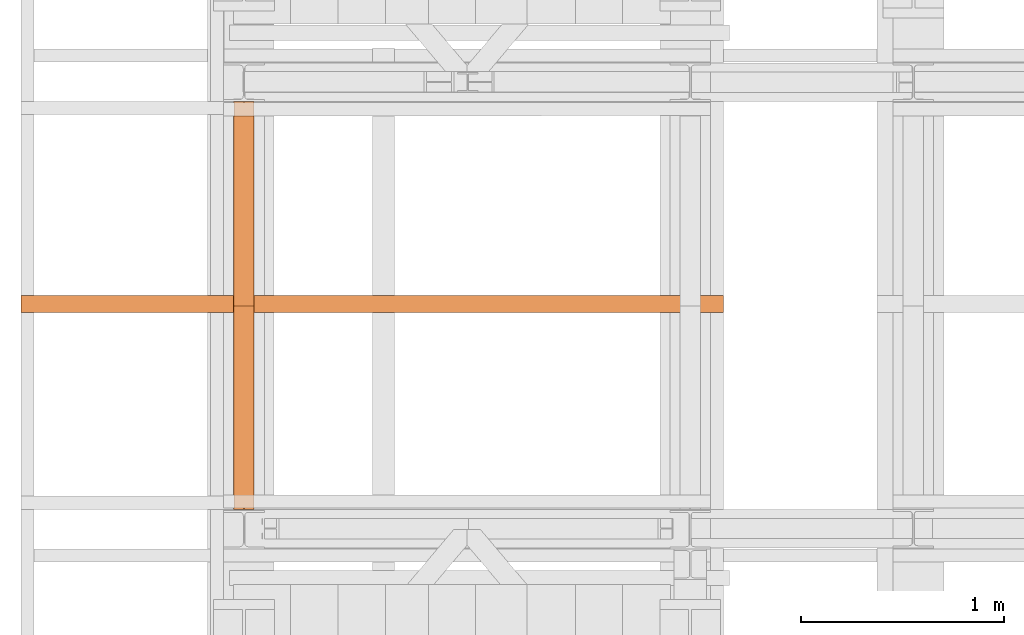
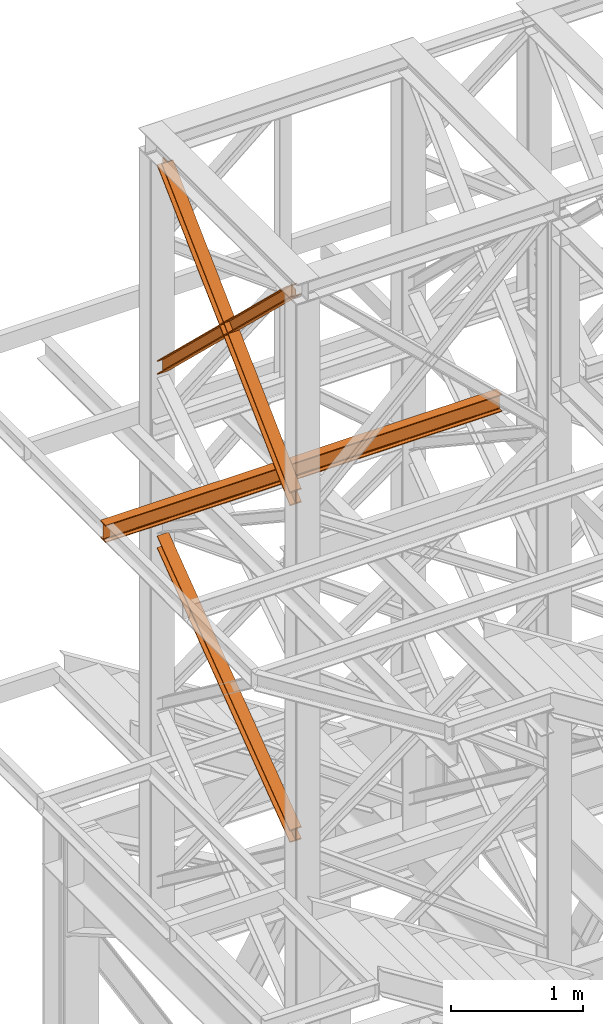
# One storey, part 96 of 208: 4 proxies.
"""IFC2X3 building model written with IfcOpenShell, lengths in millimetres."""

from ifc_helpers import new_model, entity, si_unit, converted_unit, frame, origin, origin_with_axes, place, context, subcontext, project, spatial, faceted_brep, element, save


model = new_model("IFC2X3")

# Units and contexts
model_context = context("Model", 3, precision=1e-05, world=origin())
plan_context = context("Plan", 3, precision=1e-05, world=origin())
body_context = subcontext(model_context, "Body", "Model", "MODEL_VIEW")
ifc_project = project(units=[si_unit("LENGTHUNIT", "METRE", prefix="MILLI"), converted_unit("PLANEANGLEUNIT", "DEGREE", entity("IfcPlaneAngleMeasure", 0.0174532925199433), si_unit("PLANEANGLEUNIT", "RADIAN"), dimensions=[0, 0, 0, 0, 0, 0, 0]), si_unit("AREAUNIT", "SQUARE_METRE"), si_unit("VOLUMEUNIT", "CUBIC_METRE")], contexts=[model_context, plan_context])

# Building, storey
building_placement = place(None, origin())
building = spatial("IfcBuilding", under=ifc_project, at=building_placement, CompositionType="COMPLEX")
storey_placement = place(building_placement, origin_with_axes())
storey = spatial("IfcBuildingStorey", under=building, at=storey_placement, Name="Geschoss", CompositionType="ELEMENT")

# Proxies
proxy_1_placement = place(storey_placement, frame((-3357.104352404575, -15867.5743840594, 7147.394064575148), z_axis=(0.0, 0.0, 1.0), x_axis=(1.0, 0.0, 0.0)))
element("IfcBuildingElementProxy", 1, at=proxy_1_placement, inside=storey, context=body_context, shape_type="Brep", body=[
    faceted_brep([(100.0229386519513, 2010.009987483025, 1501.524522111415), (100.185572907496, 0.01000000000021828, 0.02100513656296243), (100.1844946360361, 0.01000000000021828, 9.82075546136366), (100.0218603804915, 2010.009987483025, 1511.324272436212), (0.02293925751655479, 2010.009987483025, 1501.513516974852), (0.185573513059353, 0.01000000000021828, 0.01000000000021828), (100.185572907496, 0.01000000000021828, 0.02100513656296243), (100.0229386519513, 2010.009987483025, 1501.524522111415), (0.02186098605488951, 2010.009987483025, 1511.313267299649), (0.1844952415995067, 0.01000000000021828, 9.809750324800916), (0.185573513059353, 0.01000000000021828, 0.01000000000021828), (0.02293925751655479, 2010.009987483025, 1501.513516974852), (47.52186069841264, 2010.009987483025, 1511.318494739518), (47.68449495395544, 0.01000000000021828, 9.814977764666764), (0.1844952415995067, 0.01000000000021828, 9.809750324800916), (0.02186098605488951, 2010.009987483025, 1511.313267299649), (47.51107798381418, 2010.009987483025, 1609.315997987507), (47.67371223936061, 0.01000000000021828, 107.8124810126556), (47.68449495395544, 0.01000000000021828, 9.814977764666764), (47.52186069841264, 2010.009987483025, 1511.318494739518), (0.01107827146006457, 2010.009987483025, 1609.310770547641), (0.1737125270028628, 0.01000000000021828, 107.8072535727861), (47.67371223936061, 0.01000000000021828, 107.8124810126556), (47.51107798381418, 2010.009987483025, 1609.315997987507), (0.01000000000021828, 2010.009987483025, 1619.110520872438), (0.1726342555448355, 0.01000000000021828, 117.6070038975868), (0.1737125270028628, 0.01000000000021828, 107.8072535727861), (0.01107827146006457, 2010.009987483025, 1609.310770547641), (100.009999394435, 2010.009987483025, 1619.121526009001), (100.1726336499778, 0.01000000000021828, 117.6180090341495), (0.1726342555448355, 0.01000000000021828, 117.6070038975868), (0.01000000000021828, 2010.009987483025, 1619.110520872438), (100.0110776658949, 2010.009987483025, 1609.321775684197), (100.1737119214376, 0.01000000000021828, 107.8182587093452), (100.1726336499778, 0.01000000000021828, 117.6180090341495), (100.009999394435, 2010.009987483025, 1619.121526009001), (52.5110779535371, 2010.009987483025, 1609.316548244331), (52.67371220908353, 0.01000000000021828, 107.8130312694793), (100.1737119214376, 0.01000000000021828, 107.8182587093452), (100.0110776658949, 2010.009987483025, 1609.321775684197), (52.52186066813374, 2010.009987483025, 1511.319044996339), (52.68449492368018, 0.01000000000021828, 9.815528021497812), (52.67371220908353, 0.01000000000021828, 107.8130312694793), (52.5110779535371, 2010.009987483025, 1609.316548244331), (100.0218603804915, 2010.009987483025, 1511.324272436212), (100.1844946360361, 0.01000000000021828, 9.82075546136366), (52.68449492368018, 0.01000000000021828, 9.815528021497812), (52.52186066813374, 2010.009987483025, 1511.319044996339), (100.185572907496, 0.01000000000021828, 0.02100513656296243), (0.185573513059353, 0.01000000000021828, 0.01000000000021828), (0.1844952415995067, 0.01000000000021828, 9.809750324800916), (47.68449495395544, 0.01000000000021828, 9.814977764666764), (47.67371223936061, 0.01000000000021828, 107.8124810126556), (0.1737125270028628, 0.01000000000021828, 107.8072535727861), (0.1726342555448355, 0.01000000000021828, 117.6070038975868), (100.1726336499778, 0.01000000000021828, 117.6180090341495), (100.1737119214376, 0.01000000000021828, 107.8182587093452), (52.67371220908353, 0.01000000000021828, 107.8130312694793), (52.68449492368018, 0.01000000000021828, 9.815528021497812), (100.1844946360361, 0.01000000000021828, 9.82075546136366), (100.0218603804915, 2010.009987483025, 1511.324272436212), (52.52186066813374, 2010.009987483025, 1511.319044996339), (52.5110779535371, 2010.009987483025, 1609.316548244331), (100.0110776658949, 2010.009987483025, 1609.321775684197), (100.009999394435, 2010.009987483025, 1619.121526009001), (0.01000000000021828, 2010.009987483025, 1619.110520872438), (0.01107827146006457, 2010.009987483025, 1609.310770547641), (47.51107798381418, 2010.009987483025, 1609.315997987507), (47.52186069841264, 2010.009987483025, 1511.318494739518), (0.02186098605488951, 2010.009987483025, 1511.313267299649), (0.02293925751655479, 2010.009987483025, 1501.513516974852), (100.0229386519513, 2010.009987483025, 1501.524522111415)], [[[0, 1, 2, 3]], [[4, 5, 6, 7]], [[8, 9, 10, 11]], [[12, 13, 14, 15]], [[16, 17, 18, 19]], [[20, 21, 22, 23]], [[24, 25, 26, 27]], [[28, 29, 30, 31]], [[32, 33, 34, 35]], [[36, 37, 38, 39]], [[40, 41, 42, 43]], [[44, 45, 46, 47]], [[48, 49, 50, 51, 52, 53, 54, 55, 56, 57, 58, 59]], [[60, 61, 62, 63, 64, 65, 66, 67, 68, 69, 70, 71]]], orient=[[False], [False], [False], [False], [False], [False], [False], [False], [False], [False], [False], [False], [False], [False]]),
])
proxy_2_placement = place(storey_placement, frame((-3357.290733926031, -15867.57439014891, 10257.71351554296), z_axis=(0.0, 0.0, 1.0), x_axis=(1.0, 0.0, 0.0)))
element("IfcBuildingElementProxy", 2, at=proxy_2_placement, inside=storey, context=body_context, shape_type="Brep", body=[
    faceted_brep([(100.0212045496901, 2010.009993572538, 119.6472293306997), (100.1463438185765, 56.72628223557149, 1992.286543150845), (100.1466350609662, 68.07077152448983, 1992.286543150845), (100.0222231921616, 2010.009993572536, 130.5233411127829), (100.0222231921616, 2010.009993572536, 130.5233411127829), (100.1466350609662, 68.07077152448983, 1992.286543150845), (0.1466348943758931, 68.08252523311057, 1992.286543150842), (0.02222377857833635, 2010.009993572536, 130.5346095510231), (0.02222377857833635, 2010.009993572536, 130.5346095510231), (0.1466348943758931, 68.08252523311057, 1992.286543150842), (0.1463436519825336, 56.73803594420861, 1992.286543150842), (0.02120513611225761, 2010.009993572536, 119.6584977689327), (0.02120513611225761, 2010.009993572536, 119.6584977689327), (0.1463436519825336, 56.73803594420861, 1992.286543150842), (47.64634373111403, 56.73245293260334, 1992.286543150845), (47.52120485756132, 2010.009993572536, 119.6531452607651), (47.52120485756132, 2010.009993572536, 119.6531452607651), (47.64634373111403, 56.73245293260334, 1992.286543150845), (47.64488761591929, 0.01000608951108006, 1992.286543150845), (47.63979748861675, 0.01000608951108006, 1937.905972056111), (47.51101837541864, 2010.009993572536, 10.89202766673589), (47.51101837541864, 2010.009993572536, 10.89202766673589), (47.63979748861675, 0.01000608951108006, 1937.905972056111), (0.1397977671695116, 0.01000608951108006, 1937.911324564264), (0.011018653971405, 2010.009993572536, 10.89738017488162), (0.011018653971405, 2010.009993572536, 10.89738017488162), (0.1397977671695116, 0.01000608951108006, 1937.911324564264), (0.138779739916572, 0.01000608951108006, 1927.035210352397), (0.01000000000021828, 2010.009993572536, 0.02126843821861257), (0.01000000000021828, 2010.009993572536, 0.02126843821861257), (0.138779739916572, 0.01000608951108006, 1927.035210352397), (100.1387791534962, 0.01000608951108006, 1927.023941914182), (100.0099994135762, 2010.009993572536, 0.01000000000021828), (100.0099994135762, 2010.009993572536, 0.01000000000021828), (100.1387791534962, 0.01000608951108006, 1927.023941914182), (100.1397971807455, 0.01000608951108006, 1937.900056126053), (100.0110180675511, 2010.009993572536, 10.88611173667414), (100.0110180675511, 2010.009993572536, 10.88611173667414), (100.1397971807455, 0.01000608951108006, 1937.900056126053), (52.63979745929828, 0.01000608951108006, 1937.905408634202), (52.51101834609835, 2010.009993572536, 10.89146424482351), (52.51101834609835, 2010.009993572536, 10.89146424482351), (52.63979745929828, 0.01000608951108006, 1937.905408634202), (52.64488763917871, 0.01000000000021828, 1992.286543150845), (52.64634373944318, 56.73186524717494, 1992.286543150845), (52.52120482823921, 2010.009993572536, 119.65258183886), (52.52120482823921, 2010.009993572536, 119.65258183886), (52.64634373944318, 56.73186524717494, 1992.286543150845), (100.1463438185765, 56.72628223557149, 1992.286543150845), (100.0212045496901, 2010.009993572538, 119.6472293306997), (100.1463438185765, 56.72628223557149, 1992.286543150845), (52.64634373944318, 56.73186524717494, 1992.286543150845), (52.64488763917871, 0.01000000000021828, 1992.286543150845), (47.64488761591929, 0.01000608951108006, 1992.286543150845), (47.64634373111403, 56.73245293260334, 1992.286543150845), (0.1463436519825336, 56.73803594420861, 1992.286543150842), (0.1466348943758931, 68.08252523311057, 1992.286543150842), (100.1466350609662, 68.07077152448983, 1992.286543150845), (47.64488761591929, 0.01000608951108006, 1992.286543150845), (52.64488763917871, 0.01000000000021828, 1992.286543150845), (52.63979745929828, 0.01000608951108006, 1937.905408634202), (100.1397971807455, 0.01000608951108006, 1937.900056126053), (100.1387791534962, 0.01000608951108006, 1927.023941914182), (0.138779739916572, 0.01000608951108006, 1927.035210352397), (0.1397977671695116, 0.01000608951108006, 1937.911324564264), (47.63979748861675, 0.01000608951108006, 1937.905972056111), (100.0222231921616, 2010.009993572536, 130.5233411127829), (0.02222377857833635, 2010.009993572536, 130.5346095510231), (0.02120513611225761, 2010.009993572536, 119.6584977689327), (47.52120485756132, 2010.009993572536, 119.6531452607651), (47.51101837541864, 2010.009993572536, 10.89202766673589), (0.011018653971405, 2010.009993572536, 10.89738017488162), (0.01000000000021828, 2010.009993572536, 0.02126843821861257), (100.0099994135762, 2010.009993572536, 0.01000000000021828), (100.0110180675511, 2010.009993572536, 10.88611173667414), (52.51101834609835, 2010.009993572536, 10.89146424482351), (52.52120482823921, 2010.009993572536, 119.65258183886), (100.0212045496901, 2010.009993572538, 119.6472293306997)], [[[0, 1, 2, 3]], [[4, 5, 6, 7]], [[8, 9, 10, 11]], [[12, 13, 14, 15]], [[16, 17, 18, 19, 20]], [[21, 22, 23, 24]], [[25, 26, 27, 28]], [[29, 30, 31, 32]], [[33, 34, 35, 36]], [[37, 38, 39, 40]], [[41, 42, 43, 44, 45]], [[46, 47, 48, 49]], [[50, 51, 52, 53, 54, 55, 56, 57]], [[58, 59, 60, 61, 62, 63, 64, 65]], [[66, 67, 68, 69, 70, 71, 72, 73, 74, 75, 76, 77]]], orient=[[False], [False], [False], [False], [False], [False], [False], [False], [False], [False], [False], [False], [False], [False], [False]]),
])
proxy_3_placement = place(storey_placement, frame((-3357.270962546283, -15867.5743840594, 10261.20680675583), z_axis=(0.0, 0.0, 1.0), x_axis=(1.0, 0.0, 0.0)))
element("IfcBuildingElementProxy", 3, at=proxy_3_placement, inside=storey, context=body_context, shape_type="Brep", body=[
    faceted_brep([(100.0219376352106, 0.01000000000021828, 130.5376928144524), (100.1248673996142, 1937.888230286315, 1988.793251937981), (100.1244756427459, 1949.231612164787, 1988.793251937985), (100.0209427866557, 0.01000000000021828, 119.6603850577285), (0.02193825012000161, 0.01000000000021828, 130.5496157990219), (0.1248673541031167, 1937.875796424816, 1988.793251937981), (100.1248673996142, 1937.888230286315, 1988.793251937981), (100.0219376352106, 0.01000000000021828, 130.5376928144524), (0.02094340156691033, 0.01000000000021828, 119.6723080422798), (0.1244755972311396, 1949.21917830328, 1988.793251937981), (0.1248673541031167, 1937.875796424816, 1988.793251937981), (0.02193825012000161, 0.01000000000021828, 130.5496157990219), (47.52094310948451, 0.01000000000021828, 119.6666446246109), (47.62447561884983, 1949.225084387492, 1988.793251937981), (0.1244755972311396, 1949.21917830328, 1988.793251937981), (0.02094340156691033, 0.01000000000021828, 119.6723080422798), (47.51099456772136, 0.01000000000021828, 10.89356727918312), (47.61776178021319, 2010.009987483025, 1938.307550640491), (47.62237652174554, 2010.009987483025, 1988.793251937981), (47.62447561884983, 1949.225084387492, 1988.793251937981), (47.52094310948451, 0.01000000000021828, 119.6666446246109), (0.01099485980739701, 0.01000000000021828, 10.899230696823), (0.1177620722974098, 2010.009987483025, 1938.313214058149), (47.61776178021319, 2010.009987483025, 1938.307550640491), (47.51099456772136, 0.01000000000021828, 10.89356727918312), (0.01000000000021828, 0.01000000000021828, 0.02192298452973773), (0.1167678252622864, 2010.009987483025, 1927.43590392548), (0.1177620722974098, 2010.009987483025, 1938.313214058149), (0.01099485980739701, 0.01000000000021828, 10.899230696823), (100.0099993850836, 0.01000000000021828, 0.01000000000021828), (100.1167672103493, 2010.009987483025, 1927.42398094095), (0.1167678252622864, 2010.009987483025, 1927.43590392548), (0.01000000000021828, 0.01000000000021828, 0.02192298452973773), (100.0109942448944, 0.01000000000021828, 10.88730771230075), (100.117761457379, 2010.009987483025, 1938.301291073616), (100.1167672103493, 2010.009987483025, 1927.42398094095), (100.0099993850836, 0.01000000000021828, 0.01000000000021828), (52.51099453697134, 0.01000000000021828, 10.89297112994063), (52.61776174946681, 2010.009987483025, 1938.306954491263), (100.117761457379, 2010.009987483025, 1938.301291073616), (100.0109942448944, 0.01000000000021828, 10.88730771230075), (52.52094307873631, 0.01000000000021828, 119.6660484753793), (52.62447562112538, 1949.225706080566, 1988.793251937981), (52.62237654549062, 2010.009987483025, 1988.793251937981), (52.61776174946681, 2010.009987483025, 1938.306954491263), (52.51099453697134, 0.01000000000021828, 10.89297112994063), (100.0209427866557, 0.01000000000021828, 119.6603850577285), (100.1244756427459, 1949.231612164787, 1988.793251937985), (52.62447562112538, 1949.225706080566, 1988.793251937981), (52.52094307873631, 0.01000000000021828, 119.6660484753793), (100.1248673996142, 1937.888230286315, 1988.793251937981), (0.1248673541031167, 1937.875796424816, 1988.793251937981), (0.1244755972311396, 1949.21917830328, 1988.793251937981), (47.62447561884983, 1949.225084387492, 1988.793251937981), (47.62237652174554, 2010.009987483025, 1988.793251937981), (52.62237654549062, 2010.009987483025, 1988.793251937981), (52.62447562112538, 1949.225706080566, 1988.793251937981), (100.1244756427459, 1949.231612164787, 1988.793251937985), (47.62237652174554, 2010.009987483025, 1988.793251937981), (47.61776178021319, 2010.009987483025, 1938.307550640491), (0.1177620722974098, 2010.009987483025, 1938.313214058149), (0.1167678252622864, 2010.009987483025, 1927.43590392548), (100.1167672103493, 2010.009987483025, 1927.42398094095), (100.117761457379, 2010.009987483025, 1938.301291073616), (52.61776174946681, 2010.009987483025, 1938.306954491263), (52.62237654549062, 2010.009987483025, 1988.793251937981), (100.0209427866557, 0.01000000000021828, 119.6603850577285), (52.52094307873631, 0.01000000000021828, 119.6660484753793), (52.51099453697134, 0.01000000000021828, 10.89297112994063), (100.0109942448944, 0.01000000000021828, 10.88730771230075), (100.0099993850836, 0.01000000000021828, 0.01000000000021828), (0.01000000000021828, 0.01000000000021828, 0.02192298452973773), (0.01099485980739701, 0.01000000000021828, 10.899230696823), (47.51099456772136, 0.01000000000021828, 10.89356727918312), (47.52094310948451, 0.01000000000021828, 119.6666446246109), (0.02094340156691033, 0.01000000000021828, 119.6723080422798), (0.02193825012000161, 0.01000000000021828, 130.5496157990219), (100.0219376352106, 0.01000000000021828, 130.5376928144524)], [[[0, 1, 2, 3]], [[4, 5, 6, 7]], [[8, 9, 10, 11]], [[12, 13, 14, 15]], [[16, 17, 18, 19, 20]], [[21, 22, 23, 24]], [[25, 26, 27, 28]], [[29, 30, 31, 32]], [[33, 34, 35, 36]], [[37, 38, 39, 40]], [[41, 42, 43, 44, 45]], [[46, 47, 48, 49]], [[50, 51, 52, 53, 54, 55, 56, 57]], [[58, 59, 60, 61, 62, 63, 64, 65]], [[66, 67, 68, 69, 70, 71, 72, 73, 74, 75, 76, 77]]], orient=[[False], [False], [False], [False], [False], [False], [False], [False], [False], [False], [False], [False], [False], [False], [False]]),
])
proxy_4_placement = place(storey_placement, frame((-4406.745032961455, -14896.48556403224, 9699.99), z_axis=(0.0, 0.0, 1.0), x_axis=(1.0, 0.0, 0.0)))
element("IfcBuildingElementProxy", 4, at=proxy_4_placement, inside=storey, context=body_context, shape_type="Brep", body=[
    faceted_brep([(3465.010002980234, 0.01000000000021828, 160.0100000000002), (0.01000000000021828, 0.01000000000021828, 160.0100000000002), (0.01000000000021828, 82.01000000000022, 160.0100000000002), (3465.010002980234, 82.01000000000022, 160.0100000000002), (3465.010002980234, 82.01000000000022, 160.0100000000002), (0.01000000000021828, 82.01000000000022, 160.0100000000002), (0.01000000000021828, 82.01000000000022, 152.6099999046328), (3465.010002980234, 82.01000000000022, 152.6099999046328), (3465.010002980234, 82.01000000000022, 152.6099999046328), (0.01000000000021828, 82.01000000000022, 152.6099999046328), (0.01000000000021828, 52.51000000000022, 152.6099999046328), (3465.010002980234, 52.51000000000022, 152.6099999046328), (3465.010002980234, 52.51000000000022, 152.6099999046328), (0.01000000000021828, 52.51000000000022, 152.6099999046328), (0.01000000000021828, 50.18063640640867, 152.3033059671343), (3465.010002980234, 50.18063640640867, 152.3033059671343), (3465.010002980234, 50.18063640640867, 152.3033059671343), (0.01000000000021828, 50.18063640640867, 152.3033059671343), (0.01000000000021828, 48.01001312515291, 151.4042043652353), (3465.010002980234, 48.01001312515291, 151.4042043652353), (3465.010002980234, 48.01001312515291, 151.4042043652353), (0.01000000000021828, 48.01001312515291, 151.4042043652353), (0.01000000000021828, 46.14603896932204, 149.973960935311), (3465.010002980234, 46.14603896932204, 149.973960935311), (3465.010002980234, 46.14603896932204, 149.973960935311), (0.01000000000021828, 46.14603896932204, 149.973960935311), (0.01000000000021828, 44.71579553939591, 148.1099867794801), (3465.010002980234, 44.71579553939591, 148.1099867794801), (3465.010002980234, 44.71579553939591, 148.1099867794801), (0.01000000000021828, 44.71579553939591, 148.1099867794801), (0.01000000000021828, 43.81669393749871, 145.9393634982243), (3465.010002980234, 43.81669393749871, 145.9393634982243), (3465.010002980234, 43.81669393749871, 145.9393634982243), (0.01000000000021828, 43.81669393749871, 145.9393634982243), (0.01000000000021828, 43.51000000000022, 143.6099999046328), (3465.010002980234, 43.51000000000022, 143.6099999046328), (3465.010002980234, 43.51000000000022, 143.6099999046328), (0.01000000000021828, 43.51000000000022, 143.6099999046328), (0.01000000000021828, 43.51000000000022, 16.41000009536765), (3465.010002980234, 43.51000000000022, 16.41000009536765), (3465.010002980234, 43.51000000000022, 16.41000009536765), (0.01000000000021828, 43.51000000000022, 16.41000009536765), (0.01000000000021828, 43.81669393749871, 14.08063650177428), (3465.010002980234, 43.81669393749871, 14.08063650177428), (3465.010002980234, 43.81669393749871, 14.08063650177428), (0.01000000000021828, 43.81669393749871, 14.08063650177428), (0.01000000000021828, 44.71579553939591, 11.91001322052034), (3465.010002980234, 44.71579553939591, 11.91001322052034), (3465.010002980234, 44.71579553939591, 11.91001322052034), (0.01000000000021828, 44.71579553939591, 11.91001322052034), (0.01000000000021828, 46.14603896932204, 10.04603906468765), (3465.010002980234, 46.14603896932204, 10.04603906468765), (3465.010002980234, 46.14603896932204, 10.04603906468765), (0.01000000000021828, 46.14603896932204, 10.04603906468765), (0.01000000000021828, 48.01001312515291, 8.615795634763344), (3465.010002980234, 48.01001312515291, 8.615795634763344), (3465.010002980234, 48.01001312515291, 8.615795634763344), (0.01000000000021828, 48.01001312515291, 8.615795634763344), (0.01000000000021828, 50.18063640640867, 7.716694032864325), (3465.010002980234, 50.18063640640867, 7.716694032864325), (3465.010002980234, 50.18063640640867, 7.716694032864325), (0.01000000000021828, 50.18063640640867, 7.716694032864325), (0.01000000000021828, 52.51000000000022, 7.41000009536765), (3465.010002980234, 52.51000000000022, 7.41000009536765), (3465.010002980234, 52.51000000000022, 7.41000009536765), (0.01000000000021828, 52.51000000000022, 7.41000009536765), (0.01000000000021828, 82.01000000000022, 7.41000009536765), (3465.010002980234, 82.01000000000022, 7.41000009536765), (3465.010002980234, 82.01000000000022, 7.41000009536765), (0.01000000000021828, 82.01000000000022, 7.41000009536765), (0.01000000000021828, 82.01000000000022, 0.01000000000021828), (3465.010002980234, 82.01000000000022, 0.01000000000021828), (3465.010002980234, 82.01000000000022, 0.01000000000021828), (0.01000000000021828, 82.01000000000022, 0.01000000000021828), (0.01000000000021828, 0.01000000000021828, 0.01000000000021828), (3465.010002980234, 0.01000000000021828, 0.01000000000021828), (3465.010002980234, 0.01000000000021828, 0.01000000000021828), (0.01000000000021828, 0.01000000000021828, 0.01000000000021828), (0.01000000000021828, 0.01000000000021828, 7.41000009536765), (3465.010002980234, 0.01000000000021828, 7.41000009536765), (3465.010002980234, 0.01000000000021828, 7.41000009536765), (0.01000000000021828, 0.01000000000021828, 7.41000009536765), (0.01000000000021828, 29.51000000000022, 7.41000009536765), (3465.010002980234, 29.51000000000022, 7.41000009536765), (3465.010002980234, 29.51000000000022, 7.41000009536765), (0.01000000000021828, 29.51000000000022, 7.41000009536765), (0.01000000000021828, 31.83936359359177, 7.716694032864325), (3465.010002980234, 31.83936359359177, 7.716694032864325), (3465.010002980234, 31.83936359359177, 7.716694032864325), (0.01000000000021828, 31.83936359359177, 7.716694032864325), (0.01000000000021828, 34.00998687484753, 8.615795634763344), (3465.010002980234, 34.00998687484753, 8.615795634763344), (3465.010002980234, 34.00998687484753, 8.615795634763344), (0.01000000000021828, 34.00998687484753, 8.615795634763344), (0.01000000000021828, 35.8739610306784, 10.04603906468765), (3465.010002980234, 35.8739610306784, 10.04603906468765), (3465.010002980234, 35.8739610306784, 10.04603906468765), (0.01000000000021828, 35.8739610306784, 10.04603906468765), (0.01000000000021828, 37.30420446060452, 11.91001322052034), (3465.010002980234, 37.30420446060271, 11.91001322052034), (3465.010002980234, 37.30420446060271, 11.91001322052034), (0.01000000000021828, 37.30420446060452, 11.91001322052034), (0.01000000000021828, 38.20330606250172, 14.08063650177428), (3465.010002980234, 38.20330606250172, 14.08063650177428), (3465.010002980234, 38.20330606250172, 14.08063650177428), (0.01000000000021828, 38.20330606250172, 14.08063650177428), (0.01000000000021828, 38.51000000000022, 16.41000009536765), (3465.010002980234, 38.51000000000022, 16.41000009536765), (3465.010002980234, 38.51000000000022, 16.41000009536765), (0.01000000000021828, 38.51000000000022, 16.41000009536765), (0.01000000000021828, 38.51000000000022, 143.6099999046328), (3465.010002980234, 38.51000000000022, 143.6099999046328), (3465.010002980234, 38.51000000000022, 143.6099999046328), (0.01000000000021828, 38.51000000000022, 143.6099999046328), (0.01000000000021828, 38.20330606250172, 145.9393634982243), (3465.010002980234, 38.20330606250172, 145.9393634982243), (3465.010002980234, 38.20330606250172, 145.9393634982243), (0.01000000000021828, 38.20330606250172, 145.9393634982243), (0.01000000000021828, 37.30420446060452, 148.1099867794801), (3465.010002980234, 37.30420446060271, 148.1099867794801), (3465.010002980234, 37.30420446060271, 148.1099867794801), (0.01000000000021828, 37.30420446060452, 148.1099867794801), (0.01000000000021828, 35.8739610306784, 149.973960935311), (3465.010002980234, 35.8739610306784, 149.973960935311), (3465.010002980234, 35.8739610306784, 149.973960935311), (0.01000000000021828, 35.8739610306784, 149.973960935311), (0.01000000000021828, 34.00998687484753, 151.4042043652353), (3465.010002980234, 34.00998687484753, 151.4042043652353), (3465.010002980234, 34.00998687484753, 151.4042043652353), (0.01000000000021828, 34.00998687484753, 151.4042043652353), (0.01000000000021828, 31.83936359359177, 152.3033059671343), (3465.010002980234, 31.83936359359177, 152.3033059671343), (3465.010002980234, 31.83936359359177, 152.3033059671343), (0.01000000000021828, 31.83936359359177, 152.3033059671343), (0.01000000000021828, 29.51000000000022, 152.6099999046328), (3465.010002980234, 29.51000000000022, 152.6099999046328), (3465.010002980234, 29.51000000000022, 152.6099999046328), (0.01000000000021828, 29.51000000000022, 152.6099999046328), (0.01000000000021828, 0.01000000000021828, 152.6099999046328), (3465.010002980234, 0.01000000000021828, 152.6099999046328), (3465.010002980234, 0.01000000000021828, 152.6099999046328), (0.01000000000021828, 0.01000000000021828, 152.6099999046328), (0.01000000000021828, 0.01000000000021828, 160.0100000000002), (3465.010002980234, 0.01000000000021828, 160.0100000000002), (3465.010002980234, 0.01000000000021828, 160.0100000000002), (3465.010002980234, 82.01000000000022, 160.0100000000002), (3465.010002980234, 82.01000000000022, 152.6099999046328), (3465.010002980234, 52.51000000000022, 152.6099999046328), (3465.010002980234, 50.18063640640867, 152.3033059671343), (3465.010002980234, 48.01001312515291, 151.4042043652353), (3465.010002980234, 46.14603896932204, 149.973960935311), (3465.010002980234, 44.71579553939591, 148.1099867794801), (3465.010002980234, 43.81669393749871, 145.9393634982243), (3465.010002980234, 43.51000000000022, 143.6099999046328), (3465.010002980234, 43.51000000000022, 16.41000009536765), (3465.010002980234, 43.81669393749871, 14.08063650177428), (3465.010002980234, 44.71579553939591, 11.91001322052034), (3465.010002980234, 46.14603896932204, 10.04603906468765), (3465.010002980234, 48.01001312515291, 8.615795634763344), (3465.010002980234, 50.18063640640867, 7.716694032864325), (3465.010002980234, 52.51000000000022, 7.41000009536765), (3465.010002980234, 82.01000000000022, 7.41000009536765), (3465.010002980234, 82.01000000000022, 0.01000000000021828), (3465.010002980234, 0.01000000000021828, 0.01000000000021828), (3465.010002980234, 0.01000000000021828, 7.41000009536765), (3465.010002980234, 29.51000000000022, 7.41000009536765), (3465.010002980234, 31.83936359359177, 7.716694032864325), (3465.010002980234, 34.00998687484753, 8.615795634763344), (3465.010002980234, 35.8739610306784, 10.04603906468765), (3465.010002980234, 37.30420446060271, 11.91001322052034), (3465.010002980234, 38.20330606250172, 14.08063650177428), (3465.010002980234, 38.51000000000022, 16.41000009536765), (3465.010002980234, 38.51000000000022, 143.6099999046328), (3465.010002980234, 38.20330606250172, 145.9393634982243), (3465.010002980234, 37.30420446060271, 148.1099867794801), (3465.010002980234, 35.8739610306784, 149.973960935311), (3465.010002980234, 34.00998687484753, 151.4042043652353), (3465.010002980234, 31.83936359359177, 152.3033059671343), (3465.010002980234, 29.51000000000022, 152.6099999046328), (3465.010002980234, 0.01000000000021828, 152.6099999046328), (0.01000000000021828, 0.01000000000021828, 160.0100000000002), (0.01000000000021828, 0.01000000000021828, 152.6099999046328), (0.01000000000021828, 29.51000000000022, 152.6099999046328), (0.01000000000021828, 31.83936359359177, 152.3033059671343), (0.01000000000021828, 34.00998687484753, 151.4042043652353), (0.01000000000021828, 35.8739610306784, 149.973960935311), (0.01000000000021828, 37.30420446060452, 148.1099867794801), (0.01000000000021828, 38.20330606250172, 145.9393634982243), (0.01000000000021828, 38.51000000000022, 143.6099999046328), (0.01000000000021828, 38.51000000000022, 16.41000009536765), (0.01000000000021828, 38.20330606250172, 14.08063650177428), (0.01000000000021828, 37.30420446060452, 11.91001322052034), (0.01000000000021828, 35.8739610306784, 10.04603906468765), (0.01000000000021828, 34.00998687484753, 8.615795634763344), (0.01000000000021828, 31.83936359359177, 7.716694032864325), (0.01000000000021828, 29.51000000000022, 7.41000009536765), (0.01000000000021828, 0.01000000000021828, 7.41000009536765), (0.01000000000021828, 0.01000000000021828, 0.01000000000021828), (0.01000000000021828, 82.01000000000022, 0.01000000000021828), (0.01000000000021828, 82.01000000000022, 7.41000009536765), (0.01000000000021828, 52.51000000000022, 7.41000009536765), (0.01000000000021828, 50.18063640640867, 7.716694032864325), (0.01000000000021828, 48.01001312515291, 8.615795634763344), (0.01000000000021828, 46.14603896932204, 10.04603906468765), (0.01000000000021828, 44.71579553939591, 11.91001322052034), (0.01000000000021828, 43.81669393749871, 14.08063650177428), (0.01000000000021828, 43.51000000000022, 16.41000009536765), (0.01000000000021828, 43.51000000000022, 143.6099999046328), (0.01000000000021828, 43.81669393749871, 145.9393634982243), (0.01000000000021828, 44.71579553939591, 148.1099867794801), (0.01000000000021828, 46.14603896932204, 149.973960935311), (0.01000000000021828, 48.01001312515291, 151.4042043652353), (0.01000000000021828, 50.18063640640867, 152.3033059671343), (0.01000000000021828, 52.51000000000022, 152.6099999046328), (0.01000000000021828, 82.01000000000022, 152.6099999046328), (0.01000000000021828, 82.01000000000022, 160.0100000000002)], [[[0, 1, 2, 3]], [[4, 5, 6, 7]], [[8, 9, 10, 11]], [[12, 13, 14, 15]], [[16, 17, 18, 19]], [[20, 21, 22, 23]], [[24, 25, 26, 27]], [[28, 29, 30, 31]], [[32, 33, 34, 35]], [[36, 37, 38, 39]], [[40, 41, 42, 43]], [[44, 45, 46, 47]], [[48, 49, 50, 51]], [[52, 53, 54, 55]], [[56, 57, 58, 59]], [[60, 61, 62, 63]], [[64, 65, 66, 67]], [[68, 69, 70, 71]], [[72, 73, 74, 75]], [[76, 77, 78, 79]], [[80, 81, 82, 83]], [[84, 85, 86, 87]], [[88, 89, 90, 91]], [[92, 93, 94, 95]], [[96, 97, 98, 99]], [[100, 101, 102, 103]], [[104, 105, 106, 107]], [[108, 109, 110, 111]], [[112, 113, 114, 115]], [[116, 117, 118, 119]], [[120, 121, 122, 123]], [[124, 125, 126, 127]], [[128, 129, 130, 131]], [[132, 133, 134, 135]], [[136, 137, 138, 139]], [[140, 141, 142, 143]], [[144, 145, 146, 147, 148, 149, 150, 151, 152, 153, 154, 155, 156, 157, 158, 159, 160, 161, 162, 163, 164, 165, 166, 167, 168, 169, 170, 171, 172, 173, 174, 175, 176, 177, 178, 179]], [[180, 181, 182, 183, 184, 185, 186, 187, 188, 189, 190, 191, 192, 193, 194, 195, 196, 197, 198, 199, 200, 201, 202, 203, 204, 205, 206, 207, 208, 209, 210, 211, 212, 213, 214, 215]]], orient=[[False], [False], [False], [False], [False], [False], [False], [False], [False], [False], [False], [False], [False], [False], [False], [False], [False], [False], [False], [False], [False], [False], [False], [False], [False], [False], [False], [False], [False], [False], [False], [False], [False], [False], [False], [False], [False], [False]]),
])

save(model, "model.ifc")
